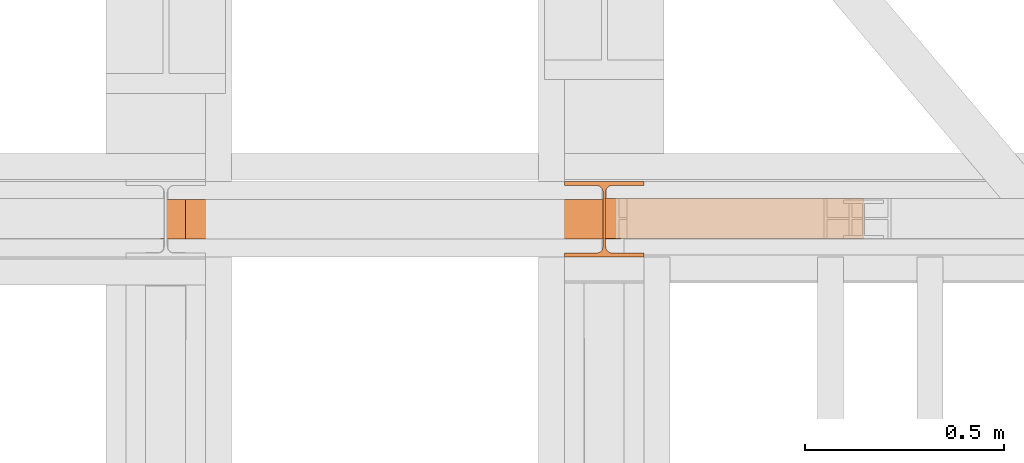
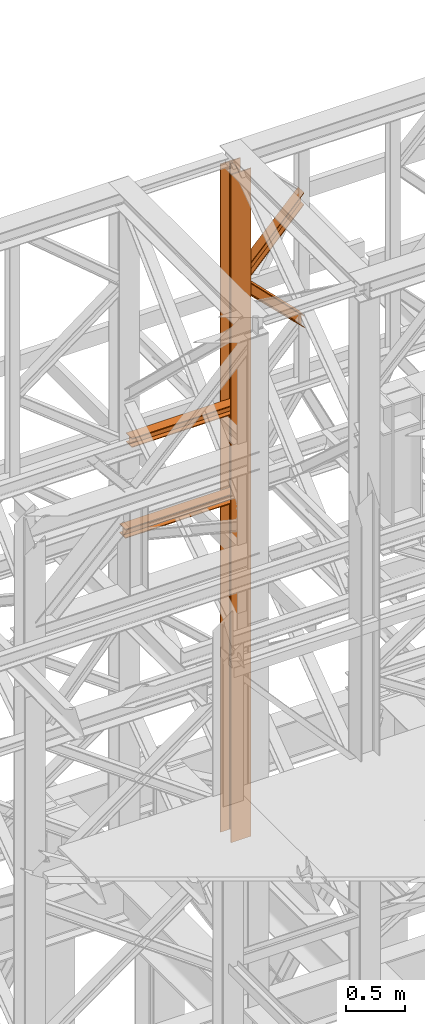
# One storey, part 130 of 208: 5 proxies.
"""IFC2X3 building model written with IfcOpenShell, lengths in millimetres."""

from ifc_helpers import new_model, entity, si_unit, converted_unit, frame, origin, origin_with_axes, place, context, subcontext, project, spatial, faceted_brep, element, save


model = new_model("IFC2X3")

# Units and contexts
model_context = context("Model", 3, precision=1e-05, world=origin())
plan_context = context("Plan", 3, precision=1e-05, world=origin())
body_context = subcontext(model_context, "Body", "Model", "MODEL_VIEW")
ifc_project = project(units=[si_unit("LENGTHUNIT", "METRE", prefix="MILLI"), converted_unit("PLANEANGLEUNIT", "DEGREE", entity("IfcPlaneAngleMeasure", 0.0174532925199433), si_unit("PLANEANGLEUNIT", "RADIAN"), dimensions=[0, 0, 0, 0, 0, 0, 0]), si_unit("AREAUNIT", "SQUARE_METRE"), si_unit("VOLUMEUNIT", "CUBIC_METRE")], contexts=[model_context, plan_context])

# Building, storey
building_placement = place(None, origin())
building = spatial("IfcBuilding", under=ifc_project, at=building_placement, CompositionType="COMPLEX")
storey_placement = place(building_placement, origin_with_axes())
storey = spatial("IfcBuildingStorey", under=building, at=storey_placement, Name="Geschoss", CompositionType="ELEMENT")

# Proxies
proxy_1_placement = place(storey_placement, frame((3193.25496703855, -13857.57439657637, 5284.990005364415), z_axis=(0.0, 0.0, 1.0), x_axis=(1.0, 0.0, 0.0)))
element("IfcBuildingElementProxy", 1, at=proxy_1_placement, inside=storey, context=body_context, shape_type="Brep", body=[
    faceted_brep([(0.01000000000021828, 190.0100125169756, 6965.010053329393), (200.0100029802325, 190.0100125169756, 6965.010053329393), (200.0100029802325, 180.0100146031382, 6965.010053329393), (121.2600035762789, 180.0100071525576, 6965.010053329393), (111.9441915473344, 178.1454621052744, 6965.010053329393), (105.1245498640838, 171.3258190250399, 6965.010053329393), (103.2600015571716, 162.010007927418, 6965.010053329393), (103.2600015571716, 28.00999713897727, 6965.010053329393), (105.1245498640838, 18.69418604135535, 6965.010053329393), (111.9441915473344, 11.87454296112082, 6965.010053329393), (121.2600035762789, 10.00999791383765, 6965.010053329393), (200.0100029802325, 10.00999791383765, 6965.010053329393), (200.0100029802325, 0.01000000000021828, 6965.010053329393), (0.01000000000021828, 0.01000000000021828, 6965.010053329393), (0.01000000000021828, 10.00999791383765, 6965.010053329393), (78.75999940395377, 10.00999791383765, 6965.010053329393), (88.07581143289826, 11.87454296112082, 6965.010053329393), (94.89545311614893, 18.69418604135535, 6965.010053329393), (96.76000142306111, 28.00999713897727, 6965.010053329393), (96.76000142306111, 162.010007927418, 6965.010053329393), (94.89545311614893, 171.3258190250399, 6965.010053329393), (88.07581143289826, 178.1454621052744, 6965.010053329393), (78.75999940395377, 180.0100071525576, 6965.010053329393), (0.01000000000021828, 180.0100146031382, 6965.010053329393), (200.0100029802325, 190.0100125169756, 6965.010053329393), (0.01000000000021828, 190.0100125169756, 6965.010053329393), (0.01000000000112777, 190.0100125169756, 0.01000000000112777), (200.0100029802334, 190.0100125169756, 0.01000000000112777), (200.0100029802325, 180.0100146031382, 6965.010053329393), (200.0100029802325, 190.0100125169756, 6965.010053329393), (200.0100029802334, 190.0100125169756, 0.01000000000112777), (200.0100029802334, 180.0100146031382, 0.01000000000112777), (121.2600035762789, 180.0100071525576, 6965.010053329393), (200.0100029802325, 180.0100146031382, 6965.010053329393), (200.0100029802334, 180.0100146031382, 0.01000000000112777), (121.2600035762798, 180.0100071525576, 0.01000000000112777), (111.9441915473344, 178.1454621052744, 6965.010053329393), (121.2600035762789, 180.0100071525576, 6965.010053329393), (121.2600035762798, 180.0100071525576, 0.01000000000112777), (111.9441915473353, 178.1454621052744, 0.01000000000112777), (105.1245498640838, 171.3258190250399, 6965.010053329393), (111.9441915473344, 178.1454621052744, 6965.010053329393), (111.9441915473353, 178.1454621052744, 0.01000000000112777), (105.1245498640847, 171.3258190250399, 0.01000000000112777), (103.2600015571716, 162.010007927418, 6965.010053329393), (105.1245498640838, 171.3258190250399, 6965.010053329393), (105.1245498640847, 171.3258190250399, 0.01000000000112777), (103.2600015571725, 162.010007927418, 0.01000000000112777), (103.2600015571716, 28.00999713897727, 6965.010053329393), (103.2600015571716, 162.010007927418, 6965.010053329393), (103.2600015571725, 162.010007927418, 0.01000000000112777), (103.2600015571725, 28.00999713897727, 0.01000000000112777), (105.1245498640838, 18.69418604135535, 6965.010053329393), (103.2600015571716, 28.00999713897727, 6965.010053329393), (103.2600015571725, 28.00999713897727, 0.01000000000112777), (105.1245498640847, 18.69418604135535, 0.01000000000112777), (111.9441915473344, 11.87454296112082, 6965.010053329393), (105.1245498640838, 18.69418604135535, 6965.010053329393), (105.1245498640847, 18.69418604135535, 0.01000000000112777), (111.9441915473353, 11.87454296112082, 0.01000000000112777), (121.2600035762789, 10.00999791383765, 6965.010053329393), (111.9441915473344, 11.87454296112082, 6965.010053329393), (111.9441915473353, 11.87454296112082, 0.01000000000112777), (121.2600035762798, 10.00999791383765, 0.01000000000112777), (200.0100029802325, 10.00999791383765, 6965.010053329393), (121.2600035762789, 10.00999791383765, 6965.010053329393), (121.2600035762798, 10.00999791383765, 0.01000000000112777), (200.0100029802334, 10.00999791383765, 0.01000000000112777), (200.0100029802325, 0.01000000000021828, 6965.010053329393), (200.0100029802325, 10.00999791383765, 6965.010053329393), (200.0100029802334, 10.00999791383765, 0.01000000000112777), (200.0100029802334, 0.01000000000021828, 0.01000000000112777), (0.01000000000021828, 0.01000000000021828, 6965.010053329393), (200.0100029802325, 0.01000000000021828, 6965.010053329393), (200.0100029802334, 0.01000000000021828, 0.01000000000112777), (0.01000000000112777, 0.01000000000021828, 0.01000000000112777), (0.01000000000021828, 10.00999791383765, 6965.010053329393), (0.01000000000021828, 0.01000000000021828, 6965.010053329393), (0.01000000000112777, 0.01000000000021828, 0.01000000000112777), (0.01000000000112777, 10.00999791383765, 0.01000000000112777), (78.75999940395377, 10.00999791383765, 6965.010053329393), (0.01000000000021828, 10.00999791383765, 6965.010053329393), (0.01000000000112777, 10.00999791383765, 0.01000000000112777), (78.75999940395468, 10.00999791383765, 0.01000000000112777), (88.07581143289826, 11.87454296112082, 6965.010053329393), (78.75999940395377, 10.00999791383765, 6965.010053329393), (78.75999940395468, 10.00999791383765, 0.01000000000112777), (88.07581143289917, 11.87454296112082, 0.01000000000112777), (94.89545311614893, 18.69418604135535, 6965.010053329393), (88.07581143289826, 11.87454296112082, 6965.010053329393), (88.07581143289917, 11.87454296112082, 0.01000000000112777), (94.89545311614984, 18.69418604135535, 0.01000000000112777), (96.76000142306111, 28.00999713897727, 6965.010053329393), (94.89545311614893, 18.69418604135535, 6965.010053329393), (94.89545311614984, 18.69418604135535, 0.01000000000112777), (96.76000142306202, 28.00999713897727, 0.01000000000112777), (96.76000142306111, 162.010007927418, 6965.010053329393), (96.76000142306111, 28.00999713897727, 6965.010053329393), (96.76000142306202, 28.00999713897727, 0.01000000000112777), (96.76000142306202, 162.010007927418, 0.01000000000112777), (94.89545311614893, 171.3258190250399, 6965.010053329393), (96.76000142306111, 162.010007927418, 6965.010053329393), (96.76000142306202, 162.010007927418, 0.01000000000112777), (94.89545311614984, 171.3258190250399, 0.01000000000112777), (88.07581143289826, 178.1454621052744, 6965.010053329393), (94.89545311614893, 171.3258190250399, 6965.010053329393), (94.89545311614984, 171.3258190250399, 0.01000000000112777), (88.07581143289917, 178.1454621052744, 0.01000000000112777), (78.75999940395377, 180.0100071525576, 6965.010053329393), (88.07581143289826, 178.1454621052744, 6965.010053329393), (88.07581143289917, 178.1454621052744, 0.01000000000112777), (78.75999940395468, 180.0100071525576, 0.01000000000112777), (0.01000000000021828, 180.0100146031382, 6965.010053329393), (78.75999940395377, 180.0100071525576, 6965.010053329393), (78.75999940395468, 180.0100071525576, 0.01000000000112777), (0.01000000000112777, 180.0100146031382, 0.01000000000112777), (0.01000000000021828, 190.0100125169756, 6965.010053329393), (0.01000000000021828, 180.0100146031382, 6965.010053329393), (0.01000000000112777, 180.0100146031382, 0.01000000000112777), (0.01000000000112777, 190.0100125169756, 0.01000000000112777), (0.01000000000112777, 190.0100125169756, 0.01000000000112777), (0.01000000000112777, 180.0100146031382, 0.01000000000112777), (78.75999940395468, 180.0100071525576, 0.01000000000112777), (88.07581143289917, 178.1454621052744, 0.01000000000112777), (94.89545311614984, 171.3258190250399, 0.01000000000112777), (96.76000142306202, 162.010007927418, 0.01000000000112777), (96.76000142306202, 28.00999713897727, 0.01000000000112777), (94.89545311614984, 18.69418604135535, 0.01000000000112777), (88.07581143289917, 11.87454296112082, 0.01000000000112777), (78.75999940395468, 10.00999791383765, 0.01000000000112777), (0.01000000000112777, 10.00999791383765, 0.01000000000112777), (0.01000000000112777, 0.01000000000021828, 0.01000000000112777), (200.0100029802334, 0.01000000000021828, 0.01000000000112777), (200.0100029802334, 10.00999791383765, 0.01000000000112777), (121.2600035762798, 10.00999791383765, 0.01000000000112777), (111.9441915473353, 11.87454296112082, 0.01000000000112777), (105.1245498640847, 18.69418604135535, 0.01000000000112777), (103.2600015571725, 28.00999713897727, 0.01000000000112777), (103.2600015571725, 162.010007927418, 0.01000000000112777), (105.1245498640847, 171.3258190250399, 0.01000000000112777), (111.9441915473353, 178.1454621052744, 0.01000000000112777), (121.2600035762798, 180.0100071525576, 0.01000000000112777), (200.0100029802334, 180.0100146031382, 0.01000000000112777), (200.0100029802334, 190.0100125169756, 0.01000000000112777)], [[[0, 1, 2, 3, 4, 5, 6, 7, 8, 9, 10, 11, 12, 13, 14, 15, 16, 17, 18, 19, 20, 21, 22, 23]], [[24, 25, 26, 27]], [[28, 29, 30, 31]], [[32, 33, 34, 35]], [[36, 37, 38, 39]], [[40, 41, 42, 43]], [[44, 45, 46, 47]], [[48, 49, 50, 51]], [[52, 53, 54, 55]], [[56, 57, 58, 59]], [[60, 61, 62, 63]], [[64, 65, 66, 67]], [[68, 69, 70, 71]], [[72, 73, 74, 75]], [[76, 77, 78, 79]], [[80, 81, 82, 83]], [[84, 85, 86, 87]], [[88, 89, 90, 91]], [[92, 93, 94, 95]], [[96, 97, 98, 99]], [[100, 101, 102, 103]], [[104, 105, 106, 107]], [[108, 109, 110, 111]], [[112, 113, 114, 115]], [[116, 117, 118, 119]], [[120, 121, 122, 123, 124, 125, 126, 127, 128, 129, 130, 131, 132, 133, 134, 135, 136, 137, 138, 139, 140, 141, 142, 143]]], orient=[[False], [False], [False], [False], [False], [False], [False], [False], [False], [False], [False], [False], [False], [False], [False], [False], [False], [False], [False], [False], [False], [False], [False], [False], [False], [False]]),
])
proxy_2_placement = place(storey_placement, frame((2242.781151314625, -13812.50587051042, 9710.105713222345), z_axis=(0.0, 0.0, 1.0), x_axis=(1.0, 0.0, 0.0)))
element("IfcBuildingElementProxy", 2, at=proxy_2_placement, inside=storey, context=body_context, shape_type="Brep", body=[
    faceted_brep([(1091.936120735611, 0.01000000000021828, 88.01000000000022), (1091.936120735611, 0.01000000000021828, 96.01000000000022), (1091.936120735611, 100.0100000000002, 96.01000000000022), (1091.936120735611, 100.0100000000002, 88.01000000000022), (1091.936120735611, 52.51000000000022, 88.01000000000022), (1091.936120735611, 52.51000000000022, 8.010000000000218), (1091.936120735611, 100.0100000000002, 8.010000000000218), (1091.936120735611, 100.0100000000002, 0.01000000000021828), (1091.936120735611, 0.01000000000021828, 0.01000000000021828), (1091.936120735611, 0.01000000000021828, 8.010000000000218), (1091.936120735611, 47.51000000000022, 8.010000000000218), (1091.936120735611, 47.51000000000022, 88.01000000000022), (1091.936120735611, 0.01000000000021828, 96.01000000000022), (1091.936120735611, 0.01000000000021828, 88.01000000000022), (0.01000000000021828, 0.01000000000385626, 88.01000000000022), (0.01000000000021828, 0.01000000000385626, 96.01000000000022), (1091.936120735611, 100.0100000000002, 96.01000000000022), (1091.936120735611, 0.01000000000021828, 96.01000000000022), (0.01000000000021828, 0.01000000000385626, 96.01000000000022), (0.01000000000021828, 100.0100000000039, 96.01000000000022), (1091.936120735611, 100.0100000000002, 88.01000000000022), (1091.936120735611, 100.0100000000002, 96.01000000000022), (0.01000000000021828, 100.0100000000039, 96.01000000000022), (0.01000000000021828, 100.0100000000039, 88.01000000000022), (1091.936120735611, 52.51000000000022, 88.01000000000022), (1091.936120735611, 100.0100000000002, 88.01000000000022), (0.01000000000021828, 100.0100000000039, 88.01000000000022), (0.01000000000021828, 52.51000000000386, 88.01000000000022), (1091.936120735611, 52.51000000000022, 8.010000000000218), (1091.936120735611, 52.51000000000022, 88.01000000000022), (0.01000000000021828, 52.51000000000386, 88.01000000000022), (0.01000000000021828, 52.51000000000386, 8.010000000000218), (1091.936120735611, 100.0100000000002, 8.010000000000218), (1091.936120735611, 52.51000000000022, 8.010000000000218), (0.01000000000021828, 52.51000000000386, 8.010000000000218), (0.01000000000021828, 100.0100000000039, 8.010000000000218), (1091.936120735611, 100.0100000000002, 0.01000000000021828), (1091.936120735611, 100.0100000000002, 8.010000000000218), (0.01000000000021828, 100.0100000000039, 8.010000000000218), (0.01000000000021828, 100.0100000000039, 0.01000000000021828), (1091.936120735611, 0.01000000000021828, 0.01000000000021828), (1091.936120735611, 100.0100000000002, 0.01000000000021828), (0.01000000000021828, 100.0100000000039, 0.01000000000021828), (0.01000000000021828, 0.01000000000385626, 0.01000000000021828), (1091.936120735611, 0.01000000000021828, 8.010000000000218), (1091.936120735611, 0.01000000000021828, 0.01000000000021828), (0.01000000000021828, 0.01000000000385626, 0.01000000000021828), (0.01000000000021828, 0.01000000000385626, 8.010000000000218), (1091.936120735611, 47.51000000000022, 8.010000000000218), (1091.936120735611, 0.01000000000021828, 8.010000000000218), (0.01000000000021828, 0.01000000000385626, 8.010000000000218), (0.01000000000021828, 47.51000000000386, 8.010000000000218), (1091.936120735611, 47.51000000000022, 88.01000000000022), (1091.936120735611, 47.51000000000022, 8.010000000000218), (0.01000000000021828, 47.51000000000386, 8.010000000000218), (0.01000000000021828, 47.51000000000386, 88.01000000000022), (1091.936120735611, 0.01000000000021828, 88.01000000000022), (1091.936120735611, 47.51000000000022, 88.01000000000022), (0.01000000000021828, 47.51000000000386, 88.01000000000022), (0.01000000000021828, 0.01000000000385626, 88.01000000000022), (0.01000000000021828, 0.01000000000385626, 88.01000000000022), (0.01000000000021828, 47.51000000000386, 88.01000000000022), (0.01000000000021828, 47.51000000000386, 8.010000000000218), (0.01000000000021828, 0.01000000000385626, 8.010000000000218), (0.01000000000021828, 0.01000000000385626, 0.01000000000021828), (0.01000000000021828, 100.0100000000039, 0.01000000000021828), (0.01000000000021828, 100.0100000000039, 8.010000000000218), (0.01000000000021828, 52.51000000000386, 8.010000000000218), (0.01000000000021828, 52.51000000000386, 88.01000000000022), (0.01000000000021828, 100.0100000000039, 88.01000000000022), (0.01000000000021828, 100.0100000000039, 96.01000000000022), (0.01000000000021828, 0.01000000000385626, 96.01000000000022)], [[[0, 1, 2, 3, 4, 5, 6, 7, 8, 9, 10, 11]], [[12, 13, 14, 15]], [[16, 17, 18, 19]], [[20, 21, 22, 23]], [[24, 25, 26, 27]], [[28, 29, 30, 31]], [[32, 33, 34, 35]], [[36, 37, 38, 39]], [[40, 41, 42, 43]], [[44, 45, 46, 47]], [[48, 49, 50, 51]], [[52, 53, 54, 55]], [[56, 57, 58, 59]], [[60, 61, 62, 63, 64, 65, 66, 67, 68, 69, 70, 71]]], orient=[[False], [False], [False], [False], [False], [False], [False], [False], [False], [False], [False], [False], [False], [False]]),
])
proxy_3_placement = place(storey_placement, frame((3293.254967038548, -13810.57439404318, 10955.2185593949), z_axis=(0.0, 0.0, 1.0), x_axis=(1.0, 0.0, 0.0)))
element("IfcBuildingElementProxy", 3, at=proxy_3_placement, inside=storey, context=body_context, shape_type="Brep", body=[
    faceted_brep([(0.01000000000158252, 0.01000000000203727, 136.1559367639657), (0.01000000000158252, 0.01000000000021828, 145.6651963377171), (647.5100014901177, 0.01000000000021828, 821.3321792650186), (647.5100014901177, 0.01000000000021828, 810.8787261814559), (0.01000000000158252, 0.01000000000021828, 145.6651963377171), (0.01000000000294676, 100.0100000000002, 145.6651963377208), (647.5100014901182, 100.0100000000002, 821.3321792650258), (647.5100014901177, 0.01000000000021828, 821.3321792650186), (0.01000000000294676, 100.0100000000002, 145.6651963377208), (0.01000000000158252, 100.0100000000002, 136.1559367639657), (647.5100014901177, 100.0100000000002, 810.8787261814559), (647.5100014901182, 100.0100000000002, 821.3321792650258), (0.01000000000158252, 100.0100000000002, 136.1559367639657), (0.0100000000052205, 52.51000000000022, 136.1559367639693), (647.5100014901168, 52.51000000000022, 810.8787261814559), (647.5100014901177, 100.0100000000002, 810.8787261814559), (0.0100000000052205, 52.51000000000022, 136.1559367639693), (0.01000000000158252, 52.51000000000022, 9.52026454738916), (647.5100014901182, 52.51000000000022, 700.4756203415545), (647.5100014901168, 52.51000000000022, 810.8787261814559), (0.01000000000158252, 52.51000000000022, 9.52026454738916), (0.01000000000021828, 100.0100000000002, 9.520264547385523), (647.5100014901209, 100.0100000000002, 700.4756203415545), (647.5100014901182, 52.51000000000022, 700.4756203415545), (0.01000000000021828, 100.0100000000002, 9.520264547385523), (0.01000000000158252, 100.0100000000002, 0.01000000000021828), (647.5100014901177, 100.0100000000002, 690.0159394275852), (647.5100014901209, 100.0100000000002, 700.4756203415545), (0.01000000000158252, 100.0100000000002, 0.01000000000021828), (0.01000000000203727, 0.01000000000021828, 0.01000000000021828), (647.5100014901182, 0.01000000000021828, 690.0159394275852), (647.5100014901177, 100.0100000000002, 690.0159394275852), (0.01000000000203727, 0.01000000000021828, 0.01000000000021828), (0.01000000000158252, 0.01000000000021828, 9.520264547392799), (647.5100014901177, 0.01000000000021828, 700.4756203415545), (647.5100014901182, 0.01000000000021828, 690.0159394275852), (0.01000000000158252, 0.01000000000021828, 9.520264547392799), (0.01000000000021828, 47.51000000000022, 9.520264547392799), (647.5100014901186, 47.51000000000022, 700.4756203415545), (647.5100014901177, 0.01000000000021828, 700.4756203415545), (0.01000000000021828, 47.51000000000022, 9.520264547392799), (0.01000000000158252, 47.51000000000022, 136.1559367639657), (647.5100014901177, 47.51000000000022, 810.8787261814559), (647.5100014901186, 47.51000000000022, 700.4756203415545), (0.01000000000158252, 47.51000000000022, 136.1559367639657), (0.01000000000158252, 0.01000000000203727, 136.1559367639657), (647.5100014901177, 0.01000000000021828, 810.8787261814559), (647.5100014901177, 47.51000000000022, 810.8787261814559), (647.5100014901177, 0.01000000000021828, 810.8787261814559), (647.5100014901177, 0.01000000000021828, 821.3321792650186), (647.5100014901182, 100.0100000000002, 821.3321792650258), (647.5100014901177, 100.0100000000002, 810.8787261814559), (647.5100014901168, 52.51000000000022, 810.8787261814559), (647.5100014901182, 52.51000000000022, 700.4756203415545), (647.5100014901209, 100.0100000000002, 700.4756203415545), (647.5100014901177, 100.0100000000002, 690.0159394275852), (647.5100014901182, 0.01000000000021828, 690.0159394275852), (647.5100014901177, 0.01000000000021828, 700.4756203415545), (647.5100014901186, 47.51000000000022, 700.4756203415545), (647.5100014901177, 47.51000000000022, 810.8787261814559), (0.01000000000158252, 0.01000000000021828, 145.6651963377171), (0.01000000000158252, 0.01000000000203727, 136.1559367639657), (0.01000000000158252, 47.51000000000022, 136.1559367639657), (0.01000000000021828, 47.51000000000022, 9.520264547392799), (0.01000000000158252, 0.01000000000021828, 9.520264547392799), (0.01000000000203727, 0.01000000000021828, 0.01000000000021828), (0.01000000000158252, 100.0100000000002, 0.01000000000021828), (0.01000000000021828, 100.0100000000002, 9.520264547385523), (0.01000000000158252, 52.51000000000022, 9.52026454738916), (0.0100000000052205, 52.51000000000022, 136.1559367639693), (0.01000000000158252, 100.0100000000002, 136.1559367639657), (0.01000000000294676, 100.0100000000002, 145.6651963377208)], [[[0, 1, 2, 3]], [[4, 5, 6, 7]], [[8, 9, 10, 11]], [[12, 13, 14, 15]], [[16, 17, 18, 19]], [[20, 21, 22, 23]], [[24, 25, 26, 27]], [[28, 29, 30, 31]], [[32, 33, 34, 35]], [[36, 37, 38, 39]], [[40, 41, 42, 43]], [[44, 45, 46, 47]], [[48, 49, 50, 51, 52, 53, 54, 55, 56, 57, 58, 59]], [[60, 61, 62, 63, 64, 65, 66, 67, 68, 69, 70, 71]]], orient=[[False], [False], [False], [False], [False], [False], [False], [False], [False], [False], [False], [False], [False], [False]]),
])
proxy_4_placement = place(storey_placement, frame((3290.004968461605, -13810.57439404318, 10364.55433028874), z_axis=(0.0, 0.0, 1.0), x_axis=(1.0, 0.0, 0.0)))
element("IfcBuildingElementProxy", 4, at=proxy_4_placement, inside=storey, context=body_context, shape_type="Brep", body=[
    faceted_brep([(0.01000000000567525, 0.01000000000203727, 771.736684541449), (0.01000000000567525, 0.01000000000021828, 780.9755634240846), (653.2600000670627, 0.01000000000021828, 127.2232754441011), (653.2600000670627, 0.01000000000021828, 117.0703501202133), (0.01000000000567525, 0.01000000000021828, 780.9755634240846), (0.01000000000476575, 100.0100000000002, 780.9755634240883), (653.260000067065, 100.0100000000002, 127.2232754441011), (653.2600000670627, 0.01000000000021828, 127.2232754441011), (0.01000000000476575, 100.0100000000002, 780.9755634240883), (0.01000000000567525, 100.0100000000002, 771.7366845414454), (653.2600000670627, 100.0100000000002, 117.0703501202133), (653.260000067065, 100.0100000000002, 127.2232754441011), (0.01000000000567525, 100.0100000000002, 771.7366845414454), (0.009999999999763531, 52.51000000000204, 771.7366845414526), (653.2600000670641, 52.51000000000022, 117.0703501202133), (653.2600000670627, 100.0100000000002, 117.0703501202133), (0.009999999999763531, 52.51000000000204, 771.7366845414526), (0.01000000000567525, 52.51000000000022, 649.4102960638211), (653.2600000670627, 52.51000000000022, 10.10333120962423), (653.2600000670641, 52.51000000000022, 117.0703501202133), (0.01000000000567525, 52.51000000000022, 649.4102960638211), (0.01000000000567525, 100.010000000002, 649.4102960638247), (653.2600000670627, 100.0100000000002, 10.10333120962787), (653.2600000670627, 52.51000000000022, 10.10333120962423), (0.01000000000567525, 100.010000000002, 649.4102960638247), (0.01000000000567525, 100.0100000000002, 640.194998598121), (653.2600000670627, 100.0100000000002, 0.01000000000385626), (653.2600000670627, 100.0100000000002, 10.10333120962787), (0.01000000000567525, 100.0100000000002, 640.194998598121), (0.01000000000567525, 0.01000000000021828, 640.194998598121), (653.2600000670627, 0.01000000000021828, 0.01000000000021828), (653.2600000670627, 100.0100000000002, 0.01000000000385626), (0.01000000000567525, 0.01000000000021828, 640.194998598121), (0.01000000000567525, 0.01000000000203727, 649.4102960638247), (653.2600000670627, 0.01000000000021828, 10.10333120962423), (653.2600000670627, 0.01000000000021828, 0.01000000000021828), (0.01000000000567525, 0.01000000000203727, 649.4102960638247), (0.01000000000567525, 47.51000000000204, 649.4102960638284), (653.2600000670627, 47.51000000000022, 10.10333120962787), (653.2600000670627, 0.01000000000021828, 10.10333120962423), (0.01000000000567525, 47.51000000000204, 649.4102960638284), (0.01000000000567525, 47.51000000000022, 771.7366845414454), (653.2600000670627, 47.51000000000022, 117.0703501202133), (653.2600000670627, 47.51000000000022, 10.10333120962787), (0.01000000000567525, 47.51000000000022, 771.7366845414454), (0.01000000000567525, 0.01000000000203727, 771.736684541449), (653.2600000670627, 0.01000000000021828, 117.0703501202133), (653.2600000670627, 47.51000000000022, 117.0703501202133), (653.2600000670627, 0.01000000000021828, 117.0703501202133), (653.2600000670627, 0.01000000000021828, 127.2232754441011), (653.260000067065, 100.0100000000002, 127.2232754441011), (653.2600000670627, 100.0100000000002, 117.0703501202133), (653.2600000670641, 52.51000000000022, 117.0703501202133), (653.2600000670627, 52.51000000000022, 10.10333120962423), (653.2600000670627, 100.0100000000002, 10.10333120962787), (653.2600000670627, 100.0100000000002, 0.01000000000385626), (653.2600000670627, 0.01000000000021828, 0.01000000000021828), (653.2600000670627, 0.01000000000021828, 10.10333120962423), (653.2600000670627, 47.51000000000022, 10.10333120962787), (653.2600000670627, 47.51000000000022, 117.0703501202133), (0.01000000000567525, 0.01000000000021828, 780.9755634240846), (0.01000000000567525, 0.01000000000203727, 771.736684541449), (0.01000000000567525, 47.51000000000022, 771.7366845414454), (0.01000000000567525, 47.51000000000204, 649.4102960638284), (0.01000000000567525, 0.01000000000203727, 649.4102960638247), (0.01000000000567525, 0.01000000000021828, 640.194998598121), (0.01000000000567525, 100.0100000000002, 640.194998598121), (0.01000000000567525, 100.010000000002, 649.4102960638247), (0.01000000000567525, 52.51000000000022, 649.4102960638211), (0.009999999999763531, 52.51000000000204, 771.7366845414526), (0.01000000000567525, 100.0100000000002, 771.7366845414454), (0.01000000000476575, 100.0100000000002, 780.9755634240883)], [[[0, 1, 2, 3]], [[4, 5, 6, 7]], [[8, 9, 10, 11]], [[12, 13, 14, 15]], [[16, 17, 18, 19]], [[20, 21, 22, 23]], [[24, 25, 26, 27]], [[28, 29, 30, 31]], [[32, 33, 34, 35]], [[36, 37, 38, 39]], [[40, 41, 42, 43]], [[44, 45, 46, 47]], [[48, 49, 50, 51, 52, 53, 54, 55, 56, 57, 58, 59]], [[60, 61, 62, 63, 64, 65, 66, 67, 68, 69, 70, 71]]], orient=[[False], [False], [False], [False], [False], [False], [False], [False], [False], [False], [False], [False], [False], [False]]),
])
proxy_5_placement = place(storey_placement, frame((2180.078845706893, -13812.50587051042, 8785.007354628784), z_axis=(0.0, 0.0, 1.0), x_axis=(1.0, 0.0, 0.0)))
element("IfcBuildingElementProxy", 5, at=proxy_5_placement, inside=storey, context=body_context, shape_type="Brep", body=[
    faceted_brep([(1091.936120735611, 0.01000000000021828, 88.01000000000022), (1091.936120735611, 0.01000000000021828, 96.01000000000022), (1091.936120735611, 100.0100000000002, 96.01000000000022), (1091.936120735611, 100.0100000000002, 88.01000000000022), (1091.936120735611, 52.51000000000022, 88.01000000000022), (1091.936120735611, 52.51000000000022, 8.010000000000218), (1091.936120735611, 100.0100000000002, 8.010000000000218), (1091.936120735611, 100.0100000000002, 0.01000000000021828), (1091.936120735611, 0.01000000000021828, 0.01000000000021828), (1091.936120735611, 0.01000000000021828, 8.010000000000218), (1091.936120735611, 47.51000000000022, 8.010000000000218), (1091.936120735611, 47.51000000000022, 88.01000000000022), (1091.936120735611, 0.01000000000021828, 96.01000000000022), (1091.936120735611, 0.01000000000021828, 88.01000000000022), (0.01000000000021828, 0.01000000000385626, 88.01000000000022), (0.01000000000021828, 0.01000000000385626, 96.01000000000022), (1091.936120735611, 100.0100000000002, 96.01000000000022), (1091.936120735611, 0.01000000000021828, 96.01000000000022), (0.01000000000021828, 0.01000000000385626, 96.01000000000022), (0.01000000000021828, 100.0100000000039, 96.01000000000022), (1091.936120735611, 100.0100000000002, 88.01000000000022), (1091.936120735611, 100.0100000000002, 96.01000000000022), (0.01000000000021828, 100.0100000000039, 96.01000000000022), (0.01000000000021828, 100.0100000000039, 88.01000000000022), (1091.936120735611, 52.51000000000022, 88.01000000000022), (1091.936120735611, 100.0100000000002, 88.01000000000022), (0.01000000000021828, 100.0100000000039, 88.01000000000022), (0.01000000000021828, 52.51000000000386, 88.01000000000022), (1091.936120735611, 52.51000000000022, 8.010000000000218), (1091.936120735611, 52.51000000000022, 88.01000000000022), (0.01000000000021828, 52.51000000000386, 88.01000000000022), (0.01000000000021828, 52.51000000000386, 8.010000000000218), (1091.936120735611, 100.0100000000002, 8.010000000000218), (1091.936120735611, 52.51000000000022, 8.010000000000218), (0.01000000000021828, 52.51000000000386, 8.010000000000218), (0.01000000000021828, 100.0100000000039, 8.010000000000218), (1091.936120735611, 100.0100000000002, 0.01000000000021828), (1091.936120735611, 100.0100000000002, 8.010000000000218), (0.01000000000021828, 100.0100000000039, 8.010000000000218), (0.01000000000021828, 100.0100000000039, 0.01000000000021828), (1091.936120735611, 0.01000000000021828, 0.01000000000021828), (1091.936120735611, 100.0100000000002, 0.01000000000021828), (0.01000000000021828, 100.0100000000039, 0.01000000000021828), (0.01000000000021828, 0.01000000000385626, 0.01000000000021828), (1091.936120735611, 0.01000000000021828, 8.010000000000218), (1091.936120735611, 0.01000000000021828, 0.01000000000021828), (0.01000000000021828, 0.01000000000385626, 0.01000000000021828), (0.01000000000021828, 0.01000000000385626, 8.010000000000218), (1091.936120735611, 47.51000000000022, 8.010000000000218), (1091.936120735611, 0.01000000000021828, 8.010000000000218), (0.01000000000021828, 0.01000000000385626, 8.010000000000218), (0.01000000000021828, 47.51000000000386, 8.010000000000218), (1091.936120735611, 47.51000000000022, 88.01000000000022), (1091.936120735611, 47.51000000000022, 8.010000000000218), (0.01000000000021828, 47.51000000000386, 8.010000000000218), (0.01000000000021828, 47.51000000000386, 88.01000000000022), (1091.936120735611, 0.01000000000021828, 88.01000000000022), (1091.936120735611, 47.51000000000022, 88.01000000000022), (0.01000000000021828, 47.51000000000386, 88.01000000000022), (0.01000000000021828, 0.01000000000385626, 88.01000000000022), (0.01000000000021828, 0.01000000000385626, 88.01000000000022), (0.01000000000021828, 47.51000000000386, 88.01000000000022), (0.01000000000021828, 47.51000000000386, 8.010000000000218), (0.01000000000021828, 0.01000000000385626, 8.010000000000218), (0.01000000000021828, 0.01000000000385626, 0.01000000000021828), (0.01000000000021828, 100.0100000000039, 0.01000000000021828), (0.01000000000021828, 100.0100000000039, 8.010000000000218), (0.01000000000021828, 52.51000000000386, 8.010000000000218), (0.01000000000021828, 52.51000000000386, 88.01000000000022), (0.01000000000021828, 100.0100000000039, 88.01000000000022), (0.01000000000021828, 100.0100000000039, 96.01000000000022), (0.01000000000021828, 0.01000000000385626, 96.01000000000022)], [[[0, 1, 2, 3, 4, 5, 6, 7, 8, 9, 10, 11]], [[12, 13, 14, 15]], [[16, 17, 18, 19]], [[20, 21, 22, 23]], [[24, 25, 26, 27]], [[28, 29, 30, 31]], [[32, 33, 34, 35]], [[36, 37, 38, 39]], [[40, 41, 42, 43]], [[44, 45, 46, 47]], [[48, 49, 50, 51]], [[52, 53, 54, 55]], [[56, 57, 58, 59]], [[60, 61, 62, 63, 64, 65, 66, 67, 68, 69, 70, 71]]], orient=[[False], [False], [False], [False], [False], [False], [False], [False], [False], [False], [False], [False], [False], [False]]),
])

save(model, "model.ifc")
